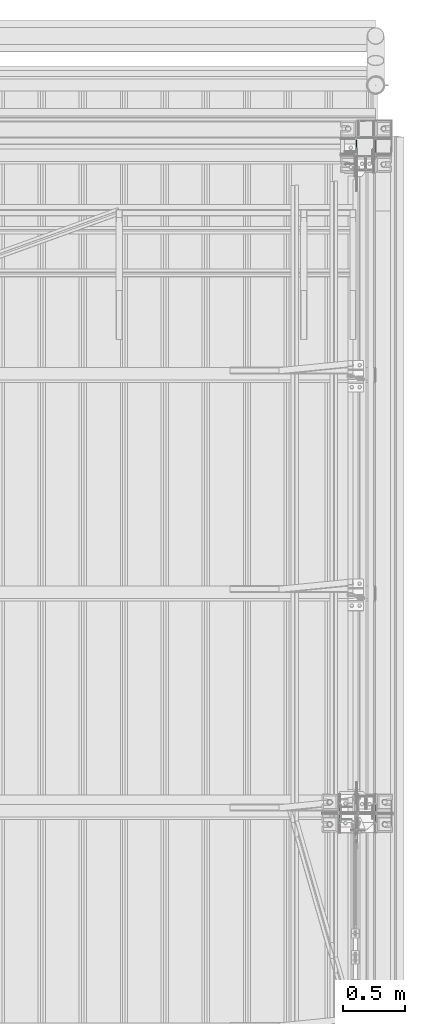
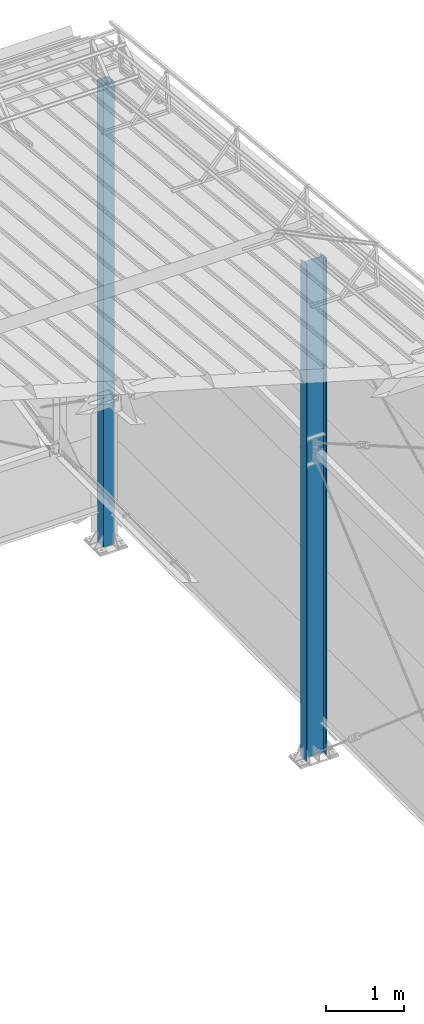
# One storey, part 239 of 709: 2 columns, 2 elements without a shape of their own.
"""IFC4 building model written with IfcOpenShell, lengths in millimetres."""

import ifcopenshell
import ifcopenshell.guid

model = None  # the IFC model being written
_history = None  # IfcOwnerHistory: only IFC2X3 demands one
_inside = {}  # id of a spatial element -> (the spatial element, [elements in it])
_under = {}  # id of a project, library or spatial element -> (it, [spatial elements below it])
_declared = {}  # id of a project -> (the project, [libraries it declares])
_typed = {}  # id of a type object -> (the type object, [elements of that type])
_made_of = {}  # id of a material, layer set ... -> (it, [elements and type objects made of it])


def new_model(schema):
    """Start an empty IFC model of exactly this schema.

    Asked for "IFC4X3", IfcOpenShell would pick the latest addendum, in which some entities
    have other attributes; the version numbers below select the first issue.
    IFC2X3 requires an IfcOwnerHistory on every rooted entity: one is made here for all.
    """
    global model, _history
    if schema == "IFC4X3":
        model = ifcopenshell.file(schema_version=(4, 3, 0, 0))
    else:
        model = ifcopenshell.file(schema=schema)
    _inside.clear()
    _under.clear()
    _declared.clear()
    _typed.clear()
    _made_of.clear()
    _history = None
    if model.schema == "IFC2X3":
        org = make("IfcOrganization", Name="unknown")
        user = make(
            "IfcPersonAndOrganization",
            ThePerson=make("IfcPerson", FamilyName="unknown"),
            TheOrganization=org,
        )
        app = make(
            "IfcApplication",
            ApplicationDeveloper=org,
            Version="unknown",
            ApplicationFullName="unknown",
            ApplicationIdentifier="unknown",
        )
        _history = make(
            "IfcOwnerHistory",
            OwningUser=user,
            OwningApplication=app,
            ChangeAction="ADDED",
            CreationDate=0,
        )
    return model


def make(cls, **values):
    """One entity of the class cls with the attributes given. An attribute that is None is left unset."""
    return model.create_entity(
        cls, **{name: value for name, value in values.items() if value is not None}
    )


def rooted(cls, **values):
    """An entity with a GlobalId (a new one), such as an element, a storey or a relation."""
    return make(cls, GlobalId=ifcopenshell.guid.new(), OwnerHistory=_history, **values)


def si_unit(unit_type, name, prefix=None):
    """IfcSIUnit, for example si_unit("LENGTHUNIT", "METRE", prefix="MILLI")."""
    return make("IfcSIUnit", UnitType=unit_type, Prefix=prefix, Name=name)


def assignment(units):
    """IfcUnitAssignment: the units of a project."""
    return None if units is None else make("IfcUnitAssignment", Units=units)


def point(xyz):
    """IfcCartesianPoint."""
    return None if xyz is None else make("IfcCartesianPoint", Coordinates=xyz)


def direction(xyz):
    """IfcDirection."""
    return None if xyz is None else make("IfcDirection", DirectionRatios=xyz)


def frame(location, z_axis=None, x_axis=None):
    """IfcAxis2Placement3D, a coordinate frame: its origin and axes. An axis left out is left unset."""
    return make(
        "IfcAxis2Placement3D",
        Location=point(location),
        Axis=direction(z_axis),
        RefDirection=direction(x_axis),
    )


def origin_with_axes():
    """The frame at (0, 0, 0) with the z axis (0, 0, 1) and the x axis (1, 0, 0) written out."""
    return frame((0.0, 0.0, 0.0), z_axis=(0.0, 0.0, 1.0), x_axis=(1.0, 0.0, 0.0))


def place(relative_to, where):
    """IfcLocalPlacement: puts the frame where relative to a parent placement (None: the world)."""
    return make(
        "IfcLocalPlacement", PlacementRelTo=relative_to, RelativePlacement=where
    )


def context(
    kind, dimensions, precision=None, world=None, true_north=None, identifier=None
):
    """IfcGeometricRepresentationContext, for example the 3D "Model" context."""
    return make(
        "IfcGeometricRepresentationContext",
        ContextIdentifier=identifier,
        ContextType=kind,
        CoordinateSpaceDimension=dimensions,
        Precision=precision,
        WorldCoordinateSystem=world,
        TrueNorth=true_north,
    )


def subcontext(parent, identifier, kind, view, scale=None):
    """IfcGeometricRepresentationSubContext, for example "Body" below "Model"."""
    return make(
        "IfcGeometricRepresentationSubContext",
        ContextIdentifier=identifier,
        ContextType=kind,
        ParentContext=parent,
        TargetScale=scale,
        TargetView=view,
    )


def project(units=None, contexts=None):
    """IfcProject with its units and contexts."""
    return rooted(
        "IfcProject",
        Name="project",
        RepresentationContexts=contexts,
        UnitsInContext=assignment(units),
    )


def spatial(cls, under=None, at=None, **own):
    """A site, building, storey or space (cls), placed at a placement, below another one or the project."""
    s = rooted(cls, ObjectPlacement=at, **own)
    if under is not None:
        _under.setdefault(under.id(), (under, []))[1].append(s)
    return s


def point_list(points):
    """IfcCartesianPointList2D or 3D."""
    cls = (
        "IfcCartesianPointList2D" if len(points[0]) == 2 else "IfcCartesianPointList3D"
    )
    return make(cls, CoordList=points)


def polygons(points, faces, closed=None, point_numbers=None):
    """IfcPolygonalFaceSet: a face is its outer loop, then its inner loops; points numbered from 1."""
    made = []
    for loops in faces:
        if len(loops) == 1:
            made.append(make("IfcIndexedPolygonalFace", CoordIndex=loops[0]))
        else:
            made.append(
                make(
                    "IfcIndexedPolygonalFaceWithVoids",
                    CoordIndex=loops[0],
                    InnerCoordIndices=loops[1:],
                )
            )
    return make(
        "IfcPolygonalFaceSet",
        Coordinates=point_list(points),
        Closed=closed,
        Faces=made,
        PnIndex=point_numbers,
    )


def shape(context_of_items, identifier, shape_type, items):
    """IfcShapeRepresentation: the items that make up one representation, for example the "Body"."""
    return make(
        "IfcShapeRepresentation",
        ContextOfItems=context_of_items,
        RepresentationIdentifier=identifier,
        RepresentationType=shape_type,
        Items=items,
    )


def material(Name=None, Category=None):
    """IfcMaterial."""
    return make("IfcMaterial", Name=Name, Category=Category)


def made_of(thing, what):
    """Note that an element or type object is made of a material, layer set ...; save() writes the relation."""
    if what is not None:
        _made_of.setdefault(what.id(), (what, []))[1].append(thing)
    return thing


def element(
    cls,
    number,
    at=None,
    inside=None,
    cuts=None,
    type_object=None,
    material=None,
    context=None,
    identifier="Body",
    shape_type=None,
    held_by="IfcProductDefinitionShape",
    body=None,
    shapes=None,
    **own,
):
    """One element of the class cls, such as IfcWall. Its Tag is "e" and its number.

    at: its placement. inside: the storey or other place that contains it. cuts: it is an
    opening in that element (IfcRelVoidsElement). A single representation is given by context,
    identifier, shape_type and body (its items); several are given by shapes. held_by: the class
    of the entity that holds the representations. save() writes the other relations.
    """
    e = rooted(cls, Tag="e%d" % number, ObjectPlacement=at, **own)
    if body is not None:
        shapes = [shape(context, identifier, shape_type, body)]
    if shapes is not None:
        e.Representation = make(held_by, Representations=shapes)
    if inside is not None:
        _inside.setdefault(inside.id(), (inside, []))[1].append(e)
    if cuts is not None:
        rooted(
            "IfcRelVoidsElement", RelatingBuildingElement=cuts, RelatedOpeningElement=e
        )
    if type_object is not None:
        _typed.setdefault(type_object.id(), (type_object, []))[1].append(e)
    return made_of(e, material)


def aggregate(whole, parts):
    """IfcRelAggregates: a whole, such as a stair, and the parts it consists of."""
    return rooted("IfcRelAggregates", RelatingObject=whole, RelatedObjects=parts)


def save(model, path):
    """Write the relations noted so far, then the file.

    IfcRelAggregates (storeys below a building ...), IfcRelContainedInSpatialStructure (elements
    in a storey), IfcRelDefinesByType, IfcRelAssociatesMaterial and IfcRelDeclares: one each for
    every whole, place, type object, material and project.
    """
    for whole, parts in _under.values():
        aggregate(whole, parts)
    for where, things in _inside.values():
        rooted(
            "IfcRelContainedInSpatialStructure",
            RelatedElements=things,
            RelatingStructure=where,
        )
    for kind, things in _typed.values():
        rooted("IfcRelDefinesByType", RelatedObjects=things, RelatingType=kind)
    for what, things in _made_of.values():
        rooted("IfcRelAssociatesMaterial", RelatedObjects=things, RelatingMaterial=what)
    for by, libraries in _declared.values():
        rooted("IfcRelDeclares", RelatingContext=by, RelatedDefinitions=libraries)
    model.write(path)


model = new_model("IFC4")

# Units and contexts
model_context = context("Model", 3, precision=0.2, world=origin_with_axes(), true_north=direction((0.0, 1.0)))
body_context = subcontext(model_context, "Body", "Model", "MODEL_VIEW")
ifc_project = project(units=[si_unit("LENGTHUNIT", "METRE", prefix="MILLI"), si_unit("AREAUNIT", "SQUARE_METRE"), si_unit("VOLUMEUNIT", "CUBIC_METRE"), si_unit("MASSUNIT", "GRAM", prefix="KILO"), si_unit("TIMEUNIT", "SECOND"), si_unit("PLANEANGLEUNIT", "RADIAN"), si_unit("SOLIDANGLEUNIT", "STERADIAN"), si_unit("THERMODYNAMICTEMPERATUREUNIT", "DEGREE_CELSIUS"), si_unit("LUMINOUSINTENSITYUNIT", "LUMEN")], contexts=[model_context])

# Site, building, storey
site_placement = place(None, origin_with_axes())
site = spatial("IfcSite", under=ifc_project, at=site_placement, CompositionType="ELEMENT")
building_placement = place(site_placement, origin_with_axes())
building = spatial("IfcBuilding", under=site, at=building_placement, Name="Undefined", CompositionType="ELEMENT")
storey_placement = place(building_placement, origin_with_axes())
storey = spatial("IfcBuildingStorey", under=building, at=storey_placement, Name="Undefined", CompositionType="ELEMENT", Elevation=0.0)

# Assembly, column
assembly_1_placement = place(storey_placement, frame((49920.0, 21920.0, -200.0), z_axis=(0.0, -1.0, 0.0), x_axis=(0.0, 0.0, 1.0)))
assembly_1 = element("IfcElementAssembly", 1, at=assembly_1_placement, inside=storey)
ifc_material = material(Name="C255-4", Category="STEEL")
column_1_placement = place(assembly_1_placement, origin_with_axes())
column_1 = element("IfcColumn", 2, at=column_1_placement, material=ifc_material, ObjectType="412", context=body_context, shape_type="Tessellation", body=[
    polygons([(25.0, -74.0, -74.0), (25.0, -74.0, 74.0), (7227.28556, -74.0, 74.0), (7212.48556, -74.0, -74.0), (25.0, 74.0, 74.0), (7227.28556, 74.0, 74.0), (25.0, 74.0, -74.0), (7212.48556, 74.0, -74.0), (25.0, -80.0, -80.0), (25.0, 80.0, -80.0), (7211.88556, 80.0, -80.0), (7211.88556, -80.0, -80.0), (25.0, 80.0, 80.0), (7227.88556, 80.0, 80.0), (25.0, -80.0, 80.0), (7227.88556, -80.0, 80.0)], [[[1, 2, 3, 4]], [[2, 5, 6, 3]], [[5, 7, 8, 6]], [[7, 1, 4, 8]], [[9, 10, 11, 12]], [[10, 13, 14, 11]], [[13, 15, 16, 14]], [[15, 9, 12, 16]], [[14, 16, 12, 11], [6, 8, 4, 3]], [[15, 13, 10, 9], [7, 5, 2, 1]]], closed=True),
])
aggregate(assembly_1, [column_1])

assembly_2_placement = place(storey_placement, frame((49851.0, 16500.0, -200.0), z_axis=(0.0, -1.0, 0.0), x_axis=(0.0, 0.0, 1.0)))
assembly_2 = element("IfcElementAssembly", 3, at=assembly_2_placement, inside=storey)
column_2_placement = place(assembly_2_placement, origin_with_axes())
column_2 = element("IfcColumn", 4, at=column_2_placement, material=ifc_material, ObjectType="414", context=body_context, shape_type="Tessellation", body=[
    polygons([(25.0, -149.0, -74.5), (25.0, -141.0, -74.5), (7750.41561, -141.0, -74.5), (7750.41561, -149.0, -74.5), (25.0, -141.0, -2.75), (7757.59061, -141.0, -2.75), (25.0, 141.0, -2.75), (7757.59061, 141.0, -2.75), (25.0, 141.0, -74.5), (7750.41561, 141.0, -74.5), (25.0, 149.0, -74.5), (7750.41561, 149.0, -74.5), (25.0, 149.0, 74.5), (7765.31561, 149.0, 74.5), (25.0, 141.0, 74.5), (7765.31561, 141.0, 74.5), (25.0, 141.0, 2.75), (7758.14061, 141.0, 2.75), (25.0, -141.0, 2.75), (7758.14061, -141.0, 2.75), (25.0, -141.0, 74.5), (7765.31561, -141.0, 74.5), (25.0, -149.0, 74.5), (7765.31561, -149.0, 74.5)], [[[1, 2, 3, 4]], [[2, 5, 6, 3]], [[5, 7, 8, 6]], [[7, 9, 10, 8]], [[9, 11, 12, 10]], [[11, 13, 14, 12]], [[13, 15, 16, 14]], [[15, 17, 18, 16]], [[17, 19, 20, 18]], [[19, 21, 22, 20]], [[21, 23, 24, 22]], [[23, 1, 4, 24]], [[6, 8, 10, 12, 14, 16, 18, 20, 22, 24, 4, 3]], [[23, 21, 19, 17, 15, 13, 11, 9, 7, 5, 2, 1]]], closed=True),
])
aggregate(assembly_2, [column_2])

save(model, "model.ifc")
